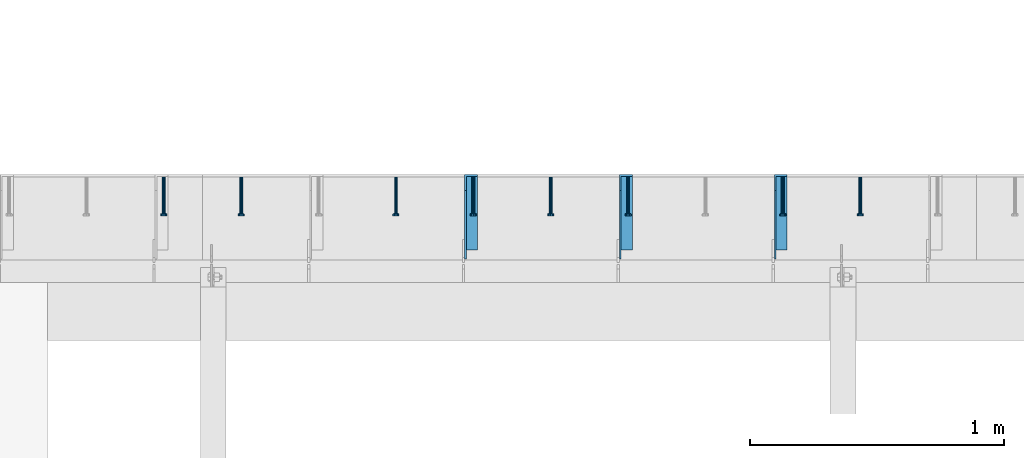
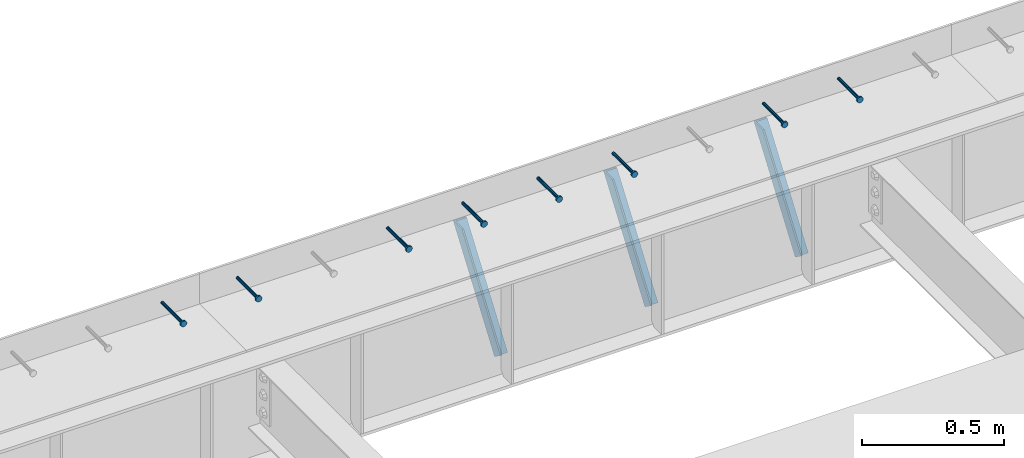
# One storey, part 1335 of 1763: 8 beams, 3 members, 9 elements without a shape of their own.
"""IFC2X3 building model written with IfcOpenShell, lengths in millimetres."""

from ifc_helpers import new_model, si_unit, frame, origin_with_axes, place, context, subcontext, project, spatial, faceted_brep, material, type_object, element, aggregate, save


model = new_model("IFC2X3")

# Units and contexts
model_context = context("Model", 3, precision=1e-05, world=origin_with_axes())
body_context = subcontext(model_context, "Body", "Model", "MODEL_VIEW")
ifc_project = project(units=[si_unit("LENGTHUNIT", "METRE", prefix="MILLI"), si_unit("AREAUNIT", "SQUARE_METRE"), si_unit("VOLUMEUNIT", "CUBIC_METRE"), si_unit("MASSUNIT", "GRAM", prefix="KILO"), si_unit("TIMEUNIT", "SECOND"), si_unit("PLANEANGLEUNIT", "RADIAN"), si_unit("SOLIDANGLEUNIT", "STERADIAN"), si_unit("THERMODYNAMICTEMPERATUREUNIT", "DEGREE_CELSIUS"), si_unit("LUMINOUSINTENSITYUNIT", "LUMEN")], contexts=[model_context])

# Site, building, storey
site_placement = place(None, origin_with_axes())
site = spatial("IfcSite", under=ifc_project, at=site_placement, CompositionType="ELEMENT")
building_placement = place(site_placement, origin_with_axes())
building = spatial("IfcBuilding", under=site, at=building_placement, Name="Undefined", CompositionType="ELEMENT")
storey_placement = place(building_placement, origin_with_axes())
storey = spatial("IfcBuildingStorey", under=building, at=storey_placement, Name="Undefined", CompositionType="ELEMENT", Elevation=0.0)

# Assembly, beam
assembly_1_placement = place(storey_placement, origin_with_axes())
assembly_1 = element("IfcElementAssembly", 1, at=assembly_1_placement, inside=storey, Name="HEADED STUD ANCHOR", AssemblyPlace="NOTDEFINED", PredefinedType="RIGID_FRAME")
ifc_material_1 = material(Name="STEEL/A108")
beam_type = type_object("IfcBeamType", PredefinedType="NOTDEFINED")
beam_1_placement = place(assembly_1_placement, frame((-82346.2372736984, 53984.5250183106, 5264.23140606069), z_axis=(0.0, 0.0, 1.0), x_axis=(0.0, -1.0, 0.0)))
beam_1 = element("IfcBeam", 2, at=beam_1_placement, type_object=beam_type, material=ifc_material_1, Name="HEADED STUD ANCHOR", context=body_context, shape_type="Brep", body=[
    faceted_brep([(0.0, -3.1800000667572, 5.5), (0.0, -5.5, 3.1800000667572), (141.732000000002, -5.5, 3.1800000667572), (141.732000000002, -3.1800000667572, 5.5), (0.0, -6.34999999999491, 1.45519152283669e-11), (141.732000000002, -6.34999990463257, 0.0), (0.0, -5.5, -3.1800000667572), (141.732000000002, -5.5, -3.1800000667572), (0.0, -3.1800000667572, -5.5), (141.732000000002, -3.1800000667572, -5.5), (0.0, 0.0, -6.34999990463257), (141.732000000002, 0.0, -6.34999990463257), (0.0, 3.1800000667572, -5.5), (141.732000000002, 3.1800000667572, -5.5), (0.0, 5.5, -3.1800000667572), (141.732000000002, 5.5, -3.1800000667572), (0.0, 6.34999999999491, -2.91038304567337e-11), (141.732000000002, 6.34999990463257, 0.0), (0.0, 5.5, 3.1800000667572), (141.732000000002, 5.5, 3.1800000667572), (0.0, 3.1800000667572, 5.5), (141.732000000002, 3.1800000667572, 5.5), (0.0, 0.0, 6.34999990463257), (141.732000000002, 0.0, 6.34999990463257), (144.780000000001, -10.9899997711182, 6.34999990463257), (144.780000000001, -6.34000015258789, 10.9899997711182), (144.780000000001, -12.6999998092651, 0.0), (144.780000000001, -10.9899997711182, -6.34999990463257), (144.780000000001, -6.34000015258789, -10.9899997711182), (144.780000000001, 0.0, -12.6899995803833), (144.780000000001, 6.34000015258789, -10.9899997711182), (144.780000000001, 10.9899997711182, -6.34999990463257), (144.780000000001, 12.6999998092651, 0.0), (144.780000000001, 10.9899997711182, 6.34999990463257), (144.780000000001, 6.34000015258789, 10.9899997711182), (144.780000000001, 0.0, 12.6899995803833), (152.400000000001, -10.9899997711182, 6.34999990463257), (152.400000000001, -6.34000015258789, 10.9899997711182), (152.400000000001, -12.6999998092651, 0.0), (152.400000000001, -10.9899997711182, -6.34999990463257), (152.400000000001, -6.34000015258789, -10.9899997711182), (152.400000000001, 0.0, -12.6899995803833), (152.400000000001, 6.34000015258789, -10.9899997711182), (152.400000000001, 10.9899997711182, -6.34999990463257), (152.400000000001, 12.6999998092651, 0.0), (152.400000000001, 10.9899997711182, 6.34999990463257), (152.400000000001, 6.34000015258789, 10.9899997711182), (152.400000000001, 0.0, 12.6899995803833)], [[[0, 1, 2, 3]], [[1, 4, 5, 2]], [[4, 6, 7, 5]], [[6, 8, 9, 7]], [[8, 10, 11, 9]], [[10, 12, 13, 11]], [[12, 14, 15, 13]], [[14, 16, 17, 15]], [[16, 18, 19, 17]], [[18, 20, 21, 19]], [[20, 22, 23, 21]], [[22, 0, 3, 23]], [[22, 20, 18, 16, 14, 12, 10, 8, 6, 4, 1, 0]], [[3, 2, 24, 25]], [[2, 5, 26, 24]], [[5, 7, 27, 26]], [[7, 9, 28, 27]], [[9, 11, 29, 28]], [[11, 13, 30, 29]], [[13, 15, 31, 30]], [[15, 17, 32, 31]], [[17, 19, 33, 32]], [[19, 21, 34, 33]], [[21, 23, 35, 34]], [[23, 3, 25, 35]], [[25, 24, 36, 37]], [[24, 26, 38, 36]], [[26, 27, 39, 38]], [[27, 28, 40, 39]], [[28, 29, 41, 40]], [[29, 30, 42, 41]], [[30, 31, 43, 42]], [[31, 32, 44, 43]], [[32, 33, 45, 44]], [[33, 34, 46, 45]], [[34, 35, 47, 46]], [[35, 25, 37, 47]], [[38, 39, 40, 41, 42, 43, 44, 45, 46, 47, 37, 36]]]),
])
aggregate(assembly_1, [beam_1])

assembly_2_placement = place(storey_placement, origin_with_axes())
assembly_2 = element("IfcElementAssembly", 3, at=assembly_2_placement, inside=storey, Name="HEADED STUD ANCHOR", AssemblyPlace="NOTDEFINED", PredefinedType="RIGID_FRAME")
beam_2_placement = place(assembly_2_placement, frame((-82651.0372736983, 53984.5250183106, 5264.23140606069), z_axis=(0.0, 0.0, 1.0), x_axis=(0.0, -1.0, 0.0)))
beam_2 = element("IfcBeam", 4, at=beam_2_placement, type_object=beam_type, material=ifc_material_1, Name="HEADED STUD ANCHOR", context=body_context, shape_type="Brep", body=[
    faceted_brep([(0.0, -3.1800000667572, 5.5), (0.0, -5.5, 3.1800000667572), (141.732000000002, -5.5, 3.1800000667572), (141.732000000002, -3.1800000667572, 5.5), (0.0, -6.34999999999491, 1.45519152283669e-11), (141.732000000002, -6.34999990463257, 0.0), (0.0, -5.5, -3.1800000667572), (141.732000000002, -5.5, -3.1800000667572), (0.0, -3.1800000667572, -5.5), (141.732000000002, -3.1800000667572, -5.5), (0.0, 0.0, -6.34999990463257), (141.732000000002, 0.0, -6.34999990463257), (0.0, 3.1800000667572, -5.5), (141.732000000002, 3.1800000667572, -5.5), (0.0, 5.5, -3.1800000667572), (141.732000000002, 5.5, -3.1800000667572), (0.0, 6.34999999999491, -2.91038304567337e-11), (141.732000000002, 6.34999990463257, 0.0), (0.0, 5.5, 3.1800000667572), (141.732000000002, 5.5, 3.1800000667572), (0.0, 3.1800000667572, 5.5), (141.732000000002, 3.1800000667572, 5.5), (0.0, 0.0, 6.34999990463257), (141.732000000002, 0.0, 6.34999990463257), (144.780000000001, -10.9899997711182, 6.34999990463257), (144.780000000001, -6.34000015258789, 10.9899997711182), (144.780000000001, -12.6999998092651, 0.0), (144.780000000001, -10.9899997711182, -6.34999990463257), (144.780000000001, -6.34000015258789, -10.9899997711182), (144.780000000001, 0.0, -12.6899995803833), (144.780000000001, 6.34000015258789, -10.9899997711182), (144.780000000001, 10.9899997711182, -6.34999990463257), (144.780000000001, 12.6999998092651, 0.0), (144.780000000001, 10.9899997711182, 6.34999990463257), (144.780000000001, 6.34000015258789, 10.9899997711182), (144.780000000001, 0.0, 12.6899995803833), (152.400000000001, -10.9899997711182, 6.34999990463257), (152.400000000001, -6.34000015258789, 10.9899997711182), (152.400000000001, -12.6999998092651, 0.0), (152.400000000001, -10.9899997711182, -6.34999990463257), (152.400000000001, -6.34000015258789, -10.9899997711182), (152.400000000001, 0.0, -12.6899995803833), (152.400000000001, 6.34000015258789, -10.9899997711182), (152.400000000001, 10.9899997711182, -6.34999990463257), (152.400000000001, 12.6999998092651, 0.0), (152.400000000001, 10.9899997711182, 6.34999990463257), (152.400000000001, 6.34000015258789, 10.9899997711182), (152.400000000001, 0.0, 12.6899995803833)], [[[0, 1, 2, 3]], [[1, 4, 5, 2]], [[4, 6, 7, 5]], [[6, 8, 9, 7]], [[8, 10, 11, 9]], [[10, 12, 13, 11]], [[12, 14, 15, 13]], [[14, 16, 17, 15]], [[16, 18, 19, 17]], [[18, 20, 21, 19]], [[20, 22, 23, 21]], [[22, 0, 3, 23]], [[22, 20, 18, 16, 14, 12, 10, 8, 6, 4, 1, 0]], [[3, 2, 24, 25]], [[2, 5, 26, 24]], [[5, 7, 27, 26]], [[7, 9, 28, 27]], [[9, 11, 29, 28]], [[11, 13, 30, 29]], [[13, 15, 31, 30]], [[15, 17, 32, 31]], [[17, 19, 33, 32]], [[19, 21, 34, 33]], [[21, 23, 35, 34]], [[23, 3, 25, 35]], [[25, 24, 36, 37]], [[24, 26, 38, 36]], [[26, 27, 39, 38]], [[27, 28, 40, 39]], [[28, 29, 41, 40]], [[29, 30, 42, 41]], [[30, 31, 43, 42]], [[31, 32, 44, 43]], [[32, 33, 45, 44]], [[33, 34, 46, 45]], [[34, 35, 47, 46]], [[35, 25, 37, 47]], [[38, 39, 40, 41, 42, 43, 44, 45, 46, 47, 37, 36]]]),
])
aggregate(assembly_2, [beam_2])

assembly_3_placement = place(storey_placement, origin_with_axes())
assembly_3 = element("IfcElementAssembly", 5, at=assembly_3_placement, inside=storey, Name="HEADED STUD ANCHOR", AssemblyPlace="NOTDEFINED", PredefinedType="RIGID_FRAME")
beam_3_placement = place(assembly_3_placement, frame((-83260.6372736983, 53984.5250183106, 5264.23140606069), z_axis=(0.0, 0.0, 1.0), x_axis=(0.0, -1.0, 0.0)))
beam_3 = element("IfcBeam", 6, at=beam_3_placement, type_object=beam_type, material=ifc_material_1, Name="HEADED STUD ANCHOR", context=body_context, shape_type="Brep", body=[
    faceted_brep([(0.0, -3.1800000667572, 5.5), (0.0, -5.5, 3.1800000667572), (141.732000000002, -5.5, 3.1800000667572), (141.732000000002, -3.1800000667572, 5.5), (0.0, -6.34999999999491, 1.45519152283669e-11), (141.732000000002, -6.34999990463257, 0.0), (0.0, -5.5, -3.1800000667572), (141.732000000002, -5.5, -3.1800000667572), (0.0, -3.1800000667572, -5.5), (141.732000000002, -3.1800000667572, -5.5), (0.0, 0.0, -6.34999990463257), (141.732000000002, 0.0, -6.34999990463257), (0.0, 3.1800000667572, -5.5), (141.732000000002, 3.1800000667572, -5.5), (0.0, 5.5, -3.1800000667572), (141.732000000002, 5.5, -3.1800000667572), (0.0, 6.34999999999491, -2.91038304567337e-11), (141.732000000002, 6.34999990463257, 0.0), (0.0, 5.5, 3.1800000667572), (141.732000000002, 5.5, 3.1800000667572), (0.0, 3.1800000667572, 5.5), (141.732000000002, 3.1800000667572, 5.5), (0.0, 0.0, 6.34999990463257), (141.732000000002, 0.0, 6.34999990463257), (144.780000000001, -10.9899997711182, 6.34999990463257), (144.780000000001, -6.34000015258789, 10.9899997711182), (144.780000000001, -12.6999998092651, 0.0), (144.780000000001, -10.9899997711182, -6.34999990463257), (144.780000000001, -6.34000015258789, -10.9899997711182), (144.780000000001, 0.0, -12.6899995803833), (144.780000000001, 6.34000015258789, -10.9899997711182), (144.780000000001, 10.9899997711182, -6.34999990463257), (144.780000000001, 12.6999998092651, 0.0), (144.780000000001, 10.9899997711182, 6.34999990463257), (144.780000000001, 6.34000015258789, 10.9899997711182), (144.780000000001, 0.0, 12.6899995803833), (152.400000000001, -10.9899997711182, 6.34999990463257), (152.400000000001, -6.34000015258789, 10.9899997711182), (152.400000000001, -12.6999998092651, 0.0), (152.400000000001, -10.9899997711182, -6.34999990463257), (152.400000000001, -6.34000015258789, -10.9899997711182), (152.400000000001, 0.0, -12.6899995803833), (152.400000000001, 6.34000015258789, -10.9899997711182), (152.400000000001, 10.9899997711182, -6.34999990463257), (152.400000000001, 12.6999998092651, 0.0), (152.400000000001, 10.9899997711182, 6.34999990463257), (152.400000000001, 6.34000015258789, 10.9899997711182), (152.400000000001, 0.0, 12.6899995803833)], [[[0, 1, 2, 3]], [[1, 4, 5, 2]], [[4, 6, 7, 5]], [[6, 8, 9, 7]], [[8, 10, 11, 9]], [[10, 12, 13, 11]], [[12, 14, 15, 13]], [[14, 16, 17, 15]], [[16, 18, 19, 17]], [[18, 20, 21, 19]], [[20, 22, 23, 21]], [[22, 0, 3, 23]], [[22, 20, 18, 16, 14, 12, 10, 8, 6, 4, 1, 0]], [[3, 2, 24, 25]], [[2, 5, 26, 24]], [[5, 7, 27, 26]], [[7, 9, 28, 27]], [[9, 11, 29, 28]], [[11, 13, 30, 29]], [[13, 15, 31, 30]], [[15, 17, 32, 31]], [[17, 19, 33, 32]], [[19, 21, 34, 33]], [[21, 23, 35, 34]], [[23, 3, 25, 35]], [[25, 24, 36, 37]], [[24, 26, 38, 36]], [[26, 27, 39, 38]], [[27, 28, 40, 39]], [[28, 29, 41, 40]], [[29, 30, 42, 41]], [[30, 31, 43, 42]], [[31, 32, 44, 43]], [[32, 33, 45, 44]], [[33, 34, 46, 45]], [[34, 35, 47, 46]], [[35, 25, 37, 47]], [[38, 39, 40, 41, 42, 43, 44, 45, 46, 47, 37, 36]]]),
])
aggregate(assembly_3, [beam_3])

assembly_4_placement = place(storey_placement, origin_with_axes())
assembly_4 = element("IfcElementAssembly", 7, at=assembly_4_placement, inside=storey, Name="HEADED STUD ANCHOR", AssemblyPlace="NOTDEFINED", PredefinedType="RIGID_FRAME")
beam_4_placement = place(assembly_4_placement, frame((-83565.4372736983, 53984.5250183106, 5264.23140606069), z_axis=(0.0, 0.0, 1.0), x_axis=(0.0, -1.0, 0.0)))
beam_4 = element("IfcBeam", 8, at=beam_4_placement, type_object=beam_type, material=ifc_material_1, Name="HEADED STUD ANCHOR", context=body_context, shape_type="Brep", body=[
    faceted_brep([(0.0, -3.1800000667572, 5.5), (0.0, -5.5, 3.1800000667572), (141.732000000002, -5.5, 3.1800000667572), (141.732000000002, -3.1800000667572, 5.5), (0.0, -6.34999999999491, 1.45519152283669e-11), (141.732000000002, -6.34999990463257, 0.0), (0.0, -5.5, -3.1800000667572), (141.732000000002, -5.5, -3.1800000667572), (0.0, -3.1800000667572, -5.5), (141.732000000002, -3.1800000667572, -5.5), (0.0, 0.0, -6.34999990463257), (141.732000000002, 0.0, -6.34999990463257), (0.0, 3.1800000667572, -5.5), (141.732000000002, 3.1800000667572, -5.5), (0.0, 5.5, -3.1800000667572), (141.732000000002, 5.5, -3.1800000667572), (0.0, 6.34999999999491, -2.91038304567337e-11), (141.732000000002, 6.34999990463257, 0.0), (0.0, 5.5, 3.1800000667572), (141.732000000002, 5.5, 3.1800000667572), (0.0, 3.1800000667572, 5.5), (141.732000000002, 3.1800000667572, 5.5), (0.0, 0.0, 6.34999990463257), (141.732000000002, 0.0, 6.34999990463257), (144.780000000001, -10.9899997711182, 6.34999990463257), (144.780000000001, -6.34000015258789, 10.9899997711182), (144.780000000001, -12.6999998092651, 0.0), (144.780000000001, -10.9899997711182, -6.34999990463257), (144.780000000001, -6.34000015258789, -10.9899997711182), (144.780000000001, 0.0, -12.6899995803833), (144.780000000001, 6.34000015258789, -10.9899997711182), (144.780000000001, 10.9899997711182, -6.34999990463257), (144.780000000001, 12.6999998092651, 0.0), (144.780000000001, 10.9899997711182, 6.34999990463257), (144.780000000001, 6.34000015258789, 10.9899997711182), (144.780000000001, 0.0, 12.6899995803833), (152.400000000001, -10.9899997711182, 6.34999990463257), (152.400000000001, -6.34000015258789, 10.9899997711182), (152.400000000001, -12.6999998092651, 0.0), (152.400000000001, -10.9899997711182, -6.34999990463257), (152.400000000001, -6.34000015258789, -10.9899997711182), (152.400000000001, 0.0, -12.6899995803833), (152.400000000001, 6.34000015258789, -10.9899997711182), (152.400000000001, 10.9899997711182, -6.34999990463257), (152.400000000001, 12.6999998092651, 0.0), (152.400000000001, 10.9899997711182, 6.34999990463257), (152.400000000001, 6.34000015258789, 10.9899997711182), (152.400000000001, 0.0, 12.6899995803833)], [[[0, 1, 2, 3]], [[1, 4, 5, 2]], [[4, 6, 7, 5]], [[6, 8, 9, 7]], [[8, 10, 11, 9]], [[10, 12, 13, 11]], [[12, 14, 15, 13]], [[14, 16, 17, 15]], [[16, 18, 19, 17]], [[18, 20, 21, 19]], [[20, 22, 23, 21]], [[22, 0, 3, 23]], [[22, 20, 18, 16, 14, 12, 10, 8, 6, 4, 1, 0]], [[3, 2, 24, 25]], [[2, 5, 26, 24]], [[5, 7, 27, 26]], [[7, 9, 28, 27]], [[9, 11, 29, 28]], [[11, 13, 30, 29]], [[13, 15, 31, 30]], [[15, 17, 32, 31]], [[17, 19, 33, 32]], [[19, 21, 34, 33]], [[21, 23, 35, 34]], [[23, 3, 25, 35]], [[25, 24, 36, 37]], [[24, 26, 38, 36]], [[26, 27, 39, 38]], [[27, 28, 40, 39]], [[28, 29, 41, 40]], [[29, 30, 42, 41]], [[30, 31, 43, 42]], [[31, 32, 44, 43]], [[32, 33, 45, 44]], [[33, 34, 46, 45]], [[34, 35, 47, 46]], [[35, 25, 37, 47]], [[38, 39, 40, 41, 42, 43, 44, 45, 46, 47, 37, 36]]]),
])
aggregate(assembly_4, [beam_4])

assembly_5_placement = place(storey_placement, origin_with_axes())
assembly_5 = element("IfcElementAssembly", 9, at=assembly_5_placement, inside=storey, Name="HEADED STUD ANCHOR", AssemblyPlace="NOTDEFINED", PredefinedType="RIGID_FRAME")
beam_5_placement = place(assembly_5_placement, frame((-83870.2372736984, 53984.5250183106, 5264.23140606069), z_axis=(0.0, 0.0, 1.0), x_axis=(0.0, -1.0, 0.0)))
beam_5 = element("IfcBeam", 10, at=beam_5_placement, type_object=beam_type, material=ifc_material_1, Name="HEADED STUD ANCHOR", context=body_context, shape_type="Brep", body=[
    faceted_brep([(0.0, -3.1800000667572, 5.5), (0.0, -5.5, 3.1800000667572), (141.732000000002, -5.5, 3.1800000667572), (141.732000000002, -3.1800000667572, 5.5), (0.0, -6.34999999999491, 1.45519152283669e-11), (141.732000000002, -6.34999990463257, 0.0), (0.0, -5.5, -3.1800000667572), (141.732000000002, -5.5, -3.1800000667572), (0.0, -3.1800000667572, -5.5), (141.732000000002, -3.1800000667572, -5.5), (0.0, 0.0, -6.34999990463257), (141.732000000002, 0.0, -6.34999990463257), (0.0, 3.1800000667572, -5.5), (141.732000000002, 3.1800000667572, -5.5), (0.0, 5.5, -3.1800000667572), (141.732000000002, 5.5, -3.1800000667572), (0.0, 6.34999999999491, -2.91038304567337e-11), (141.732000000002, 6.34999990463257, 0.0), (0.0, 5.5, 3.1800000667572), (141.732000000002, 5.5, 3.1800000667572), (0.0, 3.1800000667572, 5.5), (141.732000000002, 3.1800000667572, 5.5), (0.0, 0.0, 6.34999990463257), (141.732000000002, 0.0, 6.34999990463257), (144.780000000001, -10.9899997711182, 6.34999990463257), (144.780000000001, -6.34000015258789, 10.9899997711182), (144.780000000001, -12.6999998092651, 0.0), (144.780000000001, -10.9899997711182, -6.34999990463257), (144.780000000001, -6.34000015258789, -10.9899997711182), (144.780000000001, 0.0, -12.6899995803833), (144.780000000001, 6.34000015258789, -10.9899997711182), (144.780000000001, 10.9899997711182, -6.34999990463257), (144.780000000001, 12.6999998092651, 0.0), (144.780000000001, 10.9899997711182, 6.34999990463257), (144.780000000001, 6.34000015258789, 10.9899997711182), (144.780000000001, 0.0, 12.6899995803833), (152.400000000001, -10.9899997711182, 6.34999990463257), (152.400000000001, -6.34000015258789, 10.9899997711182), (152.400000000001, -12.6999998092651, 0.0), (152.400000000001, -10.9899997711182, -6.34999990463257), (152.400000000001, -6.34000015258789, -10.9899997711182), (152.400000000001, 0.0, -12.6899995803833), (152.400000000001, 6.34000015258789, -10.9899997711182), (152.400000000001, 10.9899997711182, -6.34999990463257), (152.400000000001, 12.6999998092651, 0.0), (152.400000000001, 10.9899997711182, 6.34999990463257), (152.400000000001, 6.34000015258789, 10.9899997711182), (152.400000000001, 0.0, 12.6899995803833)], [[[0, 1, 2, 3]], [[1, 4, 5, 2]], [[4, 6, 7, 5]], [[6, 8, 9, 7]], [[8, 10, 11, 9]], [[10, 12, 13, 11]], [[12, 14, 15, 13]], [[14, 16, 17, 15]], [[16, 18, 19, 17]], [[18, 20, 21, 19]], [[20, 22, 23, 21]], [[22, 0, 3, 23]], [[22, 20, 18, 16, 14, 12, 10, 8, 6, 4, 1, 0]], [[3, 2, 24, 25]], [[2, 5, 26, 24]], [[5, 7, 27, 26]], [[7, 9, 28, 27]], [[9, 11, 29, 28]], [[11, 13, 30, 29]], [[13, 15, 31, 30]], [[15, 17, 32, 31]], [[17, 19, 33, 32]], [[19, 21, 34, 33]], [[21, 23, 35, 34]], [[23, 3, 25, 35]], [[25, 24, 36, 37]], [[24, 26, 38, 36]], [[26, 27, 39, 38]], [[27, 28, 40, 39]], [[28, 29, 41, 40]], [[29, 30, 42, 41]], [[30, 31, 43, 42]], [[31, 32, 44, 43]], [[32, 33, 45, 44]], [[33, 34, 46, 45]], [[34, 35, 47, 46]], [[35, 25, 37, 47]], [[38, 39, 40, 41, 42, 43, 44, 45, 46, 47, 37, 36]]]),
])
aggregate(assembly_5, [beam_5])

assembly_6_placement = place(storey_placement, origin_with_axes())
assembly_6 = element("IfcElementAssembly", 11, at=assembly_6_placement, inside=storey, Name="HEADED STUD ANCHOR", AssemblyPlace="NOTDEFINED", PredefinedType="RIGID_FRAME")
beam_6_placement = place(assembly_6_placement, frame((-84175.0372736983, 53984.5250183106, 5264.23140606069), z_axis=(0.0, 0.0, 1.0), x_axis=(0.0, -1.0, 0.0)))
beam_6 = element("IfcBeam", 12, at=beam_6_placement, type_object=beam_type, material=ifc_material_1, Name="HEADED STUD ANCHOR", context=body_context, shape_type="Brep", body=[
    faceted_brep([(0.0, -3.1800000667572, 5.5), (0.0, -5.5, 3.1800000667572), (141.732000000002, -5.5, 3.1800000667572), (141.732000000002, -3.1800000667572, 5.5), (0.0, -6.34999999999491, 1.45519152283669e-11), (141.732000000002, -6.34999990463257, 0.0), (0.0, -5.5, -3.1800000667572), (141.732000000002, -5.5, -3.1800000667572), (0.0, -3.1800000667572, -5.5), (141.732000000002, -3.1800000667572, -5.5), (0.0, 0.0, -6.34999990463257), (141.732000000002, 0.0, -6.34999990463257), (0.0, 3.1800000667572, -5.5), (141.732000000002, 3.1800000667572, -5.5), (0.0, 5.5, -3.1800000667572), (141.732000000002, 5.5, -3.1800000667572), (0.0, 6.34999999999491, -2.91038304567337e-11), (141.732000000002, 6.34999990463257, 0.0), (0.0, 5.5, 3.1800000667572), (141.732000000002, 5.5, 3.1800000667572), (0.0, 3.1800000667572, 5.5), (141.732000000002, 3.1800000667572, 5.5), (0.0, 0.0, 6.34999990463257), (141.732000000002, 0.0, 6.34999990463257), (144.780000000001, -10.9899997711182, 6.34999990463257), (144.780000000001, -6.34000015258789, 10.9899997711182), (144.780000000001, -12.6999998092651, 0.0), (144.780000000001, -10.9899997711182, -6.34999990463257), (144.780000000001, -6.34000015258789, -10.9899997711182), (144.780000000001, 0.0, -12.6899995803833), (144.780000000001, 6.34000015258789, -10.9899997711182), (144.780000000001, 10.9899997711182, -6.34999990463257), (144.780000000001, 12.6999998092651, 0.0), (144.780000000001, 10.9899997711182, 6.34999990463257), (144.780000000001, 6.34000015258789, 10.9899997711182), (144.780000000001, 0.0, 12.6899995803833), (152.400000000001, -10.9899997711182, 6.34999990463257), (152.400000000001, -6.34000015258789, 10.9899997711182), (152.400000000001, -12.6999998092651, 0.0), (152.400000000001, -10.9899997711182, -6.34999990463257), (152.400000000001, -6.34000015258789, -10.9899997711182), (152.400000000001, 0.0, -12.6899995803833), (152.400000000001, 6.34000015258789, -10.9899997711182), (152.400000000001, 10.9899997711182, -6.34999990463257), (152.400000000001, 12.6999998092651, 0.0), (152.400000000001, 10.9899997711182, 6.34999990463257), (152.400000000001, 6.34000015258789, 10.9899997711182), (152.400000000001, 0.0, 12.6899995803833)], [[[0, 1, 2, 3]], [[1, 4, 5, 2]], [[4, 6, 7, 5]], [[6, 8, 9, 7]], [[8, 10, 11, 9]], [[10, 12, 13, 11]], [[12, 14, 15, 13]], [[14, 16, 17, 15]], [[16, 18, 19, 17]], [[18, 20, 21, 19]], [[20, 22, 23, 21]], [[22, 0, 3, 23]], [[22, 20, 18, 16, 14, 12, 10, 8, 6, 4, 1, 0]], [[3, 2, 24, 25]], [[2, 5, 26, 24]], [[5, 7, 27, 26]], [[7, 9, 28, 27]], [[9, 11, 29, 28]], [[11, 13, 30, 29]], [[13, 15, 31, 30]], [[15, 17, 32, 31]], [[17, 19, 33, 32]], [[19, 21, 34, 33]], [[21, 23, 35, 34]], [[23, 3, 25, 35]], [[25, 24, 36, 37]], [[24, 26, 38, 36]], [[26, 27, 39, 38]], [[27, 28, 40, 39]], [[28, 29, 41, 40]], [[29, 30, 42, 41]], [[30, 31, 43, 42]], [[31, 32, 44, 43]], [[32, 33, 45, 44]], [[33, 34, 46, 45]], [[34, 35, 47, 46]], [[35, 25, 37, 47]], [[38, 39, 40, 41, 42, 43, 44, 45, 46, 47, 37, 36]]]),
])
aggregate(assembly_6, [beam_6])

assembly_7_placement = place(storey_placement, origin_with_axes())
assembly_7 = element("IfcElementAssembly", 13, at=assembly_7_placement, inside=storey, Name="HEADED STUD ANCHOR", AssemblyPlace="NOTDEFINED", PredefinedType="RIGID_FRAME")
beam_7_placement = place(assembly_7_placement, frame((-84784.6372736983, 53984.5250183106, 5264.23140606069), z_axis=(0.0, 0.0, 1.0), x_axis=(0.0, -1.0, 0.0)))
beam_7 = element("IfcBeam", 14, at=beam_7_placement, type_object=beam_type, material=ifc_material_1, Name="HEADED STUD ANCHOR", context=body_context, shape_type="Brep", body=[
    faceted_brep([(0.0, -3.1800000667572, 5.5), (0.0, -5.5, 3.1800000667572), (141.732000000002, -5.5, 3.1800000667572), (141.732000000002, -3.1800000667572, 5.5), (0.0, -6.34999999999491, 1.45519152283669e-11), (141.732000000002, -6.34999990463257, 0.0), (0.0, -5.5, -3.1800000667572), (141.732000000002, -5.5, -3.1800000667572), (0.0, -3.1800000667572, -5.5), (141.732000000002, -3.1800000667572, -5.5), (0.0, 0.0, -6.34999990463257), (141.732000000002, 0.0, -6.34999990463257), (0.0, 3.1800000667572, -5.5), (141.732000000002, 3.1800000667572, -5.5), (0.0, 5.5, -3.1800000667572), (141.732000000002, 5.5, -3.1800000667572), (0.0, 6.34999999999491, -2.91038304567337e-11), (141.732000000002, 6.34999990463257, 0.0), (0.0, 5.5, 3.1800000667572), (141.732000000002, 5.5, 3.1800000667572), (0.0, 3.1800000667572, 5.5), (141.732000000002, 3.1800000667572, 5.5), (0.0, 0.0, 6.34999990463257), (141.732000000002, 0.0, 6.34999990463257), (144.780000000001, -10.9899997711182, 6.34999990463257), (144.780000000001, -6.34000015258789, 10.9899997711182), (144.780000000001, -12.6999998092651, 0.0), (144.780000000001, -10.9899997711182, -6.34999990463257), (144.780000000001, -6.34000015258789, -10.9899997711182), (144.780000000001, 0.0, -12.6899995803833), (144.780000000001, 6.34000015258789, -10.9899997711182), (144.780000000001, 10.9899997711182, -6.34999990463257), (144.780000000001, 12.6999998092651, 0.0), (144.780000000001, 10.9899997711182, 6.34999990463257), (144.780000000001, 6.34000015258789, 10.9899997711182), (144.780000000001, 0.0, 12.6899995803833), (152.400000000001, -10.9899997711182, 6.34999990463257), (152.400000000001, -6.34000015258789, 10.9899997711182), (152.400000000001, -12.6999998092651, 0.0), (152.400000000001, -10.9899997711182, -6.34999990463257), (152.400000000001, -6.34000015258789, -10.9899997711182), (152.400000000001, 0.0, -12.6899995803833), (152.400000000001, 6.34000015258789, -10.9899997711182), (152.400000000001, 10.9899997711182, -6.34999990463257), (152.400000000001, 12.6999998092651, 0.0), (152.400000000001, 10.9899997711182, 6.34999990463257), (152.400000000001, 6.34000015258789, 10.9899997711182), (152.400000000001, 0.0, 12.6899995803833)], [[[0, 1, 2, 3]], [[1, 4, 5, 2]], [[4, 6, 7, 5]], [[6, 8, 9, 7]], [[8, 10, 11, 9]], [[10, 12, 13, 11]], [[12, 14, 15, 13]], [[14, 16, 17, 15]], [[16, 18, 19, 17]], [[18, 20, 21, 19]], [[20, 22, 23, 21]], [[22, 0, 3, 23]], [[22, 20, 18, 16, 14, 12, 10, 8, 6, 4, 1, 0]], [[3, 2, 24, 25]], [[2, 5, 26, 24]], [[5, 7, 27, 26]], [[7, 9, 28, 27]], [[9, 11, 29, 28]], [[11, 13, 30, 29]], [[13, 15, 31, 30]], [[15, 17, 32, 31]], [[17, 19, 33, 32]], [[19, 21, 34, 33]], [[21, 23, 35, 34]], [[23, 3, 25, 35]], [[25, 24, 36, 37]], [[24, 26, 38, 36]], [[26, 27, 39, 38]], [[27, 28, 40, 39]], [[28, 29, 41, 40]], [[29, 30, 42, 41]], [[30, 31, 43, 42]], [[31, 32, 44, 43]], [[32, 33, 45, 44]], [[33, 34, 46, 45]], [[34, 35, 47, 46]], [[35, 25, 37, 47]], [[38, 39, 40, 41, 42, 43, 44, 45, 46, 47, 37, 36]]]),
])
aggregate(assembly_7, [beam_7])

assembly_8_placement = place(storey_placement, origin_with_axes())
assembly_8 = element("IfcElementAssembly", 15, at=assembly_8_placement, inside=storey, Name="HEADED STUD ANCHOR", AssemblyPlace="NOTDEFINED", PredefinedType="RIGID_FRAME")
beam_8_placement = place(assembly_8_placement, frame((-85089.4372736983, 53984.5250183106, 5264.23140606069), z_axis=(0.0, 0.0, 1.0), x_axis=(0.0, -1.0, 0.0)))
beam_8 = element("IfcBeam", 16, at=beam_8_placement, type_object=beam_type, material=ifc_material_1, Name="HEADED STUD ANCHOR", context=body_context, shape_type="Brep", body=[
    faceted_brep([(0.0, -3.1800000667572, 5.5), (0.0, -5.5, 3.1800000667572), (141.732000000002, -5.5, 3.1800000667572), (141.732000000002, -3.1800000667572, 5.5), (0.0, -6.34999999999491, 1.45519152283669e-11), (141.732000000002, -6.34999990463257, 0.0), (0.0, -5.5, -3.1800000667572), (141.732000000002, -5.5, -3.1800000667572), (0.0, -3.1800000667572, -5.5), (141.732000000002, -3.1800000667572, -5.5), (0.0, 0.0, -6.34999990463257), (141.732000000002, 0.0, -6.34999990463257), (0.0, 3.1800000667572, -5.5), (141.732000000002, 3.1800000667572, -5.5), (0.0, 5.5, -3.1800000667572), (141.732000000002, 5.5, -3.1800000667572), (0.0, 6.34999999999491, -2.91038304567337e-11), (141.732000000002, 6.34999990463257, 0.0), (0.0, 5.5, 3.1800000667572), (141.732000000002, 5.5, 3.1800000667572), (0.0, 3.1800000667572, 5.5), (141.732000000002, 3.1800000667572, 5.5), (0.0, 0.0, 6.34999990463257), (141.732000000002, 0.0, 6.34999990463257), (144.780000000001, -10.9899997711182, 6.34999990463257), (144.780000000001, -6.34000015258789, 10.9899997711182), (144.780000000001, -12.6999998092651, 0.0), (144.780000000001, -10.9899997711182, -6.34999990463257), (144.780000000001, -6.34000015258789, -10.9899997711182), (144.780000000001, 0.0, -12.6899995803833), (144.780000000001, 6.34000015258789, -10.9899997711182), (144.780000000001, 10.9899997711182, -6.34999990463257), (144.780000000001, 12.6999998092651, 0.0), (144.780000000001, 10.9899997711182, 6.34999990463257), (144.780000000001, 6.34000015258789, 10.9899997711182), (144.780000000001, 0.0, 12.6899995803833), (152.400000000001, -10.9899997711182, 6.34999990463257), (152.400000000001, -6.34000015258789, 10.9899997711182), (152.400000000001, -12.6999998092651, 0.0), (152.400000000001, -10.9899997711182, -6.34999990463257), (152.400000000001, -6.34000015258789, -10.9899997711182), (152.400000000001, 0.0, -12.6899995803833), (152.400000000001, 6.34000015258789, -10.9899997711182), (152.400000000001, 10.9899997711182, -6.34999990463257), (152.400000000001, 12.6999998092651, 0.0), (152.400000000001, 10.9899997711182, 6.34999990463257), (152.400000000001, 6.34000015258789, 10.9899997711182), (152.400000000001, 0.0, 12.6899995803833)], [[[0, 1, 2, 3]], [[1, 4, 5, 2]], [[4, 6, 7, 5]], [[6, 8, 9, 7]], [[8, 10, 11, 9]], [[10, 12, 13, 11]], [[12, 14, 15, 13]], [[14, 16, 17, 15]], [[16, 18, 19, 17]], [[18, 20, 21, 19]], [[20, 22, 23, 21]], [[22, 0, 3, 23]], [[22, 20, 18, 16, 14, 12, 10, 8, 6, 4, 1, 0]], [[3, 2, 24, 25]], [[2, 5, 26, 24]], [[5, 7, 27, 26]], [[7, 9, 28, 27]], [[9, 11, 29, 28]], [[11, 13, 30, 29]], [[13, 15, 31, 30]], [[15, 17, 32, 31]], [[17, 19, 33, 32]], [[19, 21, 34, 33]], [[21, 23, 35, 34]], [[23, 3, 25, 35]], [[25, 24, 36, 37]], [[24, 26, 38, 36]], [[26, 27, 39, 38]], [[27, 28, 40, 39]], [[28, 29, 41, 40]], [[29, 30, 42, 41]], [[30, 31, 43, 42]], [[31, 32, 44, 43]], [[32, 33, 45, 44]], [[33, 34, 46, 45]], [[34, 35, 47, 46]], [[35, 25, 37, 47]], [[38, 39, 40, 41, 42, 43, 44, 45, 46, 47, 37, 36]]]),
])
aggregate(assembly_8, [beam_8])

# Assembly, members
assembly_9_placement = place(storey_placement, origin_with_axes())
assembly_9 = element("IfcElementAssembly", 17, at=assembly_9_placement, inside=storey, Name="BEAM", AssemblyPlace="NOTDEFINED", PredefinedType="RIGID_FRAME")
ifc_material_2 = material(Name="STEEL/A36")
member_type = type_object("IfcMemberType", Name="L2X2X1/4", PredefinedType="NOTDEFINED")
member_1_placement = place(assembly_9_placement, frame((-83268.9716486984, 53682.7083833994, 4801.55161052494), z_axis=(0.0, -0.814117947745209, 0.580699549818259), x_axis=(0.0, 0.58069954981826, 0.814117947745209)))
member_1 = element("IfcMember", 18, at=member_1_placement, type_object=member_type, material=ifc_material_2, Name="ANGLE", ObjectType="L2X2X1/4", context=body_context, shape_type="Brep", body=[
    faceted_brep([(-1.45519152283669e-11, 25.4000000000015, -25.3999999999869), (1.45519152283669e-11, 25.4000000000015, 25.3999999999796), (464.304493432646, 25.4000000000015, 25.3999999991429), (500.539460322936, 25.4000000000015, -25.4000000009546), (1.45519152283669e-11, 19.0499999999993, 25.3999999999796), (464.304493432646, 19.0500000000029, 25.3999999991429), (-7.27595761418343e-12, 19.0499999999993, -19.0499999999956), (496.010089461648, 19.0500000000029, -19.0500000009415), (-7.27595761418343e-12, -25.4000000000015, -19.0499999999956), (496.010089461648, -25.4000000000015, -19.0500000009415), (-1.45519152283669e-11, -25.4000000000015, -25.3999999999869), (500.539460322936, -25.4000000000015, -25.4000000009546)], [[[0, 1, 2, 3]], [[1, 4, 5, 2]], [[4, 6, 7, 5]], [[6, 8, 9, 7]], [[8, 10, 11, 9]], [[10, 0, 3, 11]], [[5, 7, 9, 11, 3, 2]], [[10, 8, 6, 4, 1, 0]]]),
])
member_2_placement = place(assembly_9_placement, frame((-82659.3716486984, 53682.7083833994, 4801.55161052494), z_axis=(0.0, -0.814117947745209, 0.580699549818259), x_axis=(0.0, 0.58069954981826, 0.814117947745209)))
member_2 = element("IfcMember", 19, at=member_2_placement, type_object=member_type, material=ifc_material_2, Name="ANGLE", ObjectType="L2X2X1/4", context=body_context, shape_type="Brep", body=[
    faceted_brep([(-1.45519152283669e-11, 25.4000000000015, -25.3999999999869), (1.45519152283669e-11, 25.4000000000015, 25.3999999999796), (464.304493432646, 25.4000000000015, 25.3999999991429), (500.539460322936, 25.4000000000015, -25.4000000009546), (1.45519152283669e-11, 19.0499999999993, 25.3999999999796), (464.304493432646, 19.0500000000029, 25.3999999991429), (-7.27595761418343e-12, 19.0499999999993, -19.0499999999956), (496.010089461648, 19.0500000000029, -19.0500000009415), (-7.27595761418343e-12, -25.4000000000015, -19.0499999999956), (496.010089461648, -25.4000000000015, -19.0500000009415), (-1.45519152283669e-11, -25.4000000000015, -25.3999999999869), (500.539460322936, -25.4000000000015, -25.4000000009546)], [[[0, 1, 2, 3]], [[1, 4, 5, 2]], [[4, 6, 7, 5]], [[6, 8, 9, 7]], [[8, 10, 11, 9]], [[10, 0, 3, 11]], [[5, 7, 9, 11, 3, 2]], [[10, 8, 6, 4, 1, 0]]]),
])
member_3_placement = place(assembly_9_placement, frame((-83878.5716486984, 53682.7083833994, 4801.55161052494), z_axis=(0.0, -0.814117947745209, 0.580699549818259), x_axis=(0.0, 0.58069954981826, 0.814117947745209)))
member_3 = element("IfcMember", 20, at=member_3_placement, type_object=member_type, material=ifc_material_2, Name="ANGLE", ObjectType="L2X2X1/4", context=body_context, shape_type="Brep", body=[
    faceted_brep([(-1.45519152283669e-11, 25.4000000000015, -25.3999999999869), (1.45519152283669e-11, 25.4000000000015, 25.3999999999796), (464.304493432646, 25.4000000000015, 25.3999999991429), (500.539460322936, 25.4000000000015, -25.4000000009546), (1.45519152283669e-11, 19.0499999999993, 25.3999999999796), (464.304493432646, 19.0500000000029, 25.3999999991429), (-7.27595761418343e-12, 19.0499999999993, -19.0499999999956), (496.010089461648, 19.0500000000029, -19.0500000009415), (-7.27595761418343e-12, -25.4000000000015, -19.0499999999956), (496.010089461648, -25.4000000000015, -19.0500000009415), (-1.45519152283669e-11, -25.4000000000015, -25.3999999999869), (500.539460322936, -25.4000000000015, -25.4000000009546)], [[[0, 1, 2, 3]], [[1, 4, 5, 2]], [[4, 6, 7, 5]], [[6, 8, 9, 7]], [[8, 10, 11, 9]], [[10, 0, 3, 11]], [[5, 7, 9, 11, 3, 2]], [[10, 8, 6, 4, 1, 0]]]),
])
aggregate(assembly_9, [member_1, member_2, member_3])

save(model, "model.ifc")
